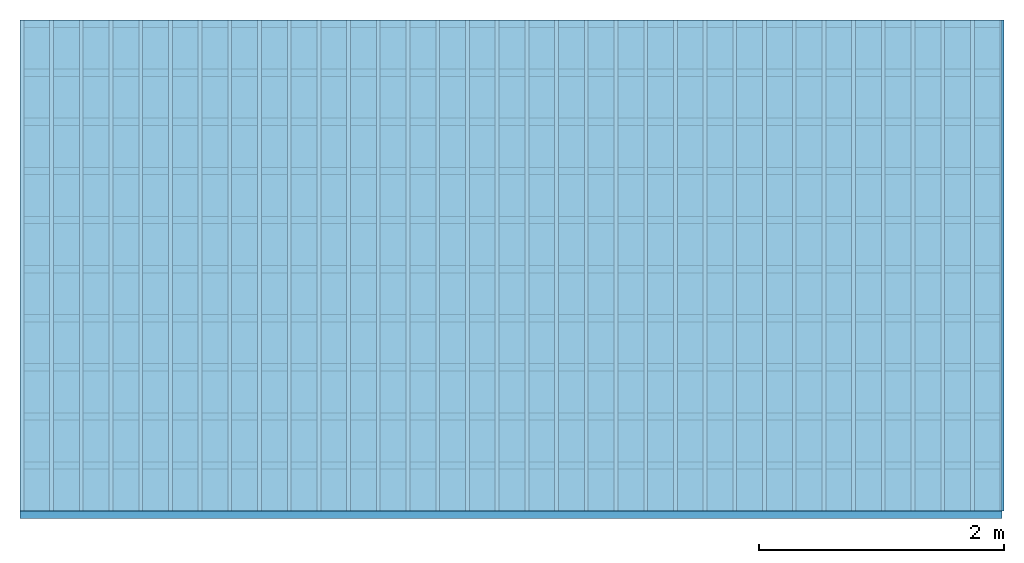
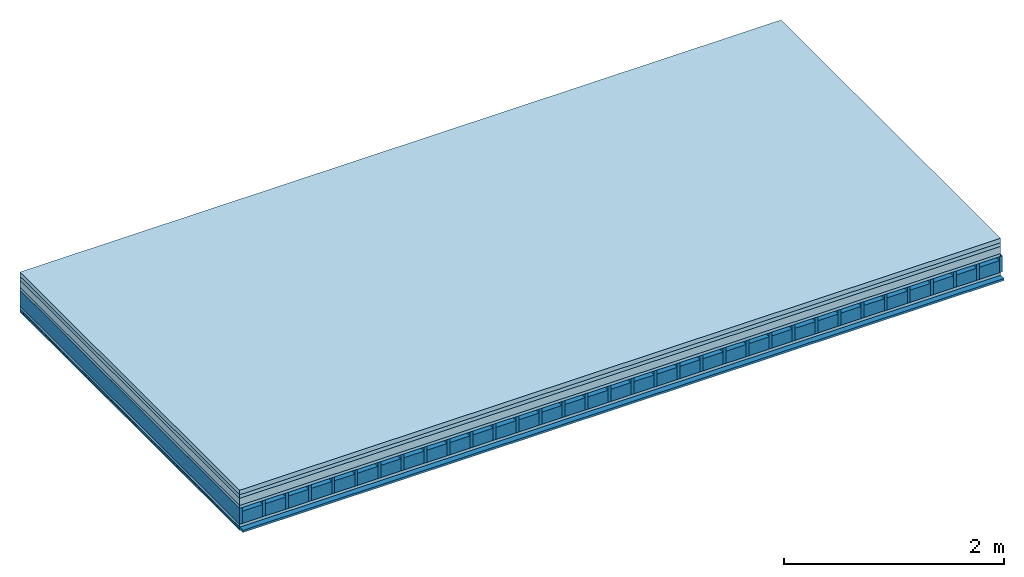
# One storey: 6 plates, 4 members, 1 element without a shape of its own.
"""IFC4 building model written with IfcOpenShell, lengths in metres."""

from ifc_helpers import new_model, si_unit, derived_unit, direction, frame, frame_2d, origin, origin_with_axes, place, context, project, spatial, rectangle, extrude, material, layer, layer_set, type_object, element, aggregate, save


model = new_model("IFC4")

# Units and contexts
plan_context = context("Plan", 3, precision=1e-05, world=origin(), true_north=direction((0.0, 1.0)))
model_context = context("Model", 3, precision=1e-05, world=origin(), true_north=direction((0.0, 1.0)))
ifc_project = project(units=[si_unit("LENGTHUNIT", "METRE"), derived_unit("SOUNDPRESSUREUNIT", [(si_unit("PRESSUREUNIT", "PASCAL", prefix="MICRO"), 0)]), si_unit("ENERGYUNIT", "JOULE", prefix="MEGA"), si_unit("MASSUNIT", "GRAM", prefix="KILO"), derived_unit("THERMALTRANSMITTANCEUNIT", [(si_unit("POWERUNIT", "WATT"), 1), (si_unit("AREAUNIT", "SQUARE_METRE"), -1), (si_unit("THERMODYNAMICTEMPERATUREUNIT", "KELVIN"), -1)]), derived_unit("AREADENSITYUNIT", [(si_unit("MASSUNIT", "GRAM", prefix="KILO"), 1), (si_unit("AREAUNIT", "SQUARE_METRE"), -1)]), derived_unit("USERDEFINED", [(si_unit("ENERGYUNIT", "JOULE", prefix="MEGA"), 1), (si_unit("AREAUNIT", "SQUARE_METRE"), -1)])], contexts=[plan_context, model_context])

# Site, building, storey
site = spatial("IfcSite", under=ifc_project)
building_placement = place(None, origin())
building = spatial("IfcBuilding", under=site, at=building_placement)
storey_placement = place(building_placement, origin())
storey = spatial("IfcBuildingStorey", under=building, at=storey_placement)

# Slab, members, plates
ifc_material_1 = material(Name="Cement screed", Category="04.006")
ifc_layer_1 = layer(ifc_material_1, 0.05, Name="On-material")
ifc_material_2 = material(Name="EP1, 40/35mm")
ifc_layer_2 = layer(ifc_material_2, 0.04, Name="Impact sound insulation")
ifc_material_3 = material(Category="03.011")
ifc_layer_3 = layer(ifc_material_3, 0.08, Name="on Supporting structure")
ifc_material_4 = material(Name="surface element sheathing above")
ifc_layer_4 = layer(ifc_material_4, 0.031, Name="Sub-floor")
ifc_layer_5 = layer(None, 0.178, Name="Supporting structure")
ifc_material_5 = material(Name="surface element sheathing below")
ifc_layer_6 = layer(ifc_material_5, 0.031, Name="Lower layer 1")
ifc_layer_7 = layer(None, 0.024, Name="Battens / profiles")
ifc_material_6 = material(Name="Plasterboard type A", Category="03.008")
ifc_layer_8 = layer(ifc_material_6, 0.0125, Name="Ceiling covering 1st layer")
ifc_material_7 = material(Name="joints", Category="04.017")
ifc_layer_9 = layer(ifc_material_7, 0.0, Name="Surface / treatment")
ifc_layer_set = layer_set([ifc_layer_1, ifc_layer_2, ifc_layer_3, ifc_layer_4, ifc_layer_5, ifc_layer_6, ifc_layer_7, ifc_layer_8, ifc_layer_9])
slab_type = type_object("IfcSlabType", Name="A1468", PredefinedType="NOTDEFINED", material=ifc_layer_set)
slab_placement = place(None, frame((0.0, 0.0, 0.0), z_axis=(0.0, 0.0, -1.0), x_axis=(1.0, 0.0, 0.0)))
slab = element("IfcSlab", 1, at=slab_placement, inside=storey, type_object=slab_type, material=ifc_layer_set, Name="Slab #1")
ifc_material_8 = material(Name="surface element LFE 12")
member_1_placement = place(slab_placement, origin())
member_1 = element("IfcMember", 2, at=member_1_placement, material=ifc_material_8, Name="Supporting structure", context=plan_context, shape_type="SweptSolid", body=[
    extrude(rectangle(XDim=0.031, YDim=0.178, at=frame_2d((0.0155, 0.089), x_axis=(1.0, 0.0))), frame((0.0, 4.0, 0.201), z_axis=(0.0, -1.0, 0.0), x_axis=(1.0, 0.0, 0.0)), (0.0, 0.0, 1.0), 4.0),
    extrude(rectangle(XDim=0.031, YDim=0.178, at=frame_2d((0.0155, 0.089), x_axis=(1.0, 0.0))), frame((0.242, 4.0, 0.201), z_axis=(0.0, -1.0, 0.0), x_axis=(1.0, 0.0, 0.0)), (0.0, 0.0, 1.0), 4.0),
    extrude(rectangle(XDim=0.031, YDim=0.178, at=frame_2d((0.0155, 0.089), x_axis=(1.0, 0.0))), frame((0.484, 4.0, 0.201), z_axis=(0.0, -1.0, 0.0), x_axis=(1.0, 0.0, 0.0)), (0.0, 0.0, 1.0), 4.0),
    extrude(rectangle(XDim=0.031, YDim=0.178, at=frame_2d((0.0155, 0.089), x_axis=(1.0, 0.0))), frame((0.726, 4.0, 0.201), z_axis=(0.0, -1.0, 0.0), x_axis=(1.0, 0.0, 0.0)), (0.0, 0.0, 1.0), 4.0),
    extrude(rectangle(XDim=0.031, YDim=0.178, at=frame_2d((0.0155, 0.089), x_axis=(1.0, 0.0))), frame((0.968, 4.0, 0.201), z_axis=(0.0, -1.0, 0.0), x_axis=(1.0, 0.0, 0.0)), (0.0, 0.0, 1.0), 4.0),
    extrude(rectangle(XDim=0.031, YDim=0.178, at=frame_2d((0.0155, 0.089), x_axis=(1.0, 0.0))), frame((1.21, 4.0, 0.201), z_axis=(0.0, -1.0, 0.0), x_axis=(1.0, 0.0, 0.0)), (0.0, 0.0, 1.0), 4.0),
    extrude(rectangle(XDim=0.031, YDim=0.178, at=frame_2d((0.0155, 0.089), x_axis=(1.0, 0.0))), frame((1.452, 4.0, 0.201), z_axis=(0.0, -1.0, 0.0), x_axis=(1.0, 0.0, 0.0)), (0.0, 0.0, 1.0), 4.0),
    extrude(rectangle(XDim=0.031, YDim=0.178, at=frame_2d((0.0155, 0.089), x_axis=(1.0, 0.0))), frame((1.694, 4.0, 0.201), z_axis=(0.0, -1.0, 0.0), x_axis=(1.0, 0.0, 0.0)), (0.0, 0.0, 1.0), 4.0),
    extrude(rectangle(XDim=0.031, YDim=0.178, at=frame_2d((0.0155, 0.089), x_axis=(1.0, 0.0))), frame((1.936, 4.0, 0.201), z_axis=(0.0, -1.0, 0.0), x_axis=(1.0, 0.0, 0.0)), (0.0, 0.0, 1.0), 4.0),
    extrude(rectangle(XDim=0.031, YDim=0.178, at=frame_2d((0.0155, 0.089), x_axis=(1.0, 0.0))), frame((2.178, 4.0, 0.201), z_axis=(0.0, -1.0, 0.0), x_axis=(1.0, 0.0, 0.0)), (0.0, 0.0, 1.0), 4.0),
    extrude(rectangle(XDim=0.031, YDim=0.178, at=frame_2d((0.0155, 0.089), x_axis=(1.0, 0.0))), frame((2.42, 4.0, 0.201), z_axis=(0.0, -1.0, 0.0), x_axis=(1.0, 0.0, 0.0)), (0.0, 0.0, 1.0), 4.0),
    extrude(rectangle(XDim=0.031, YDim=0.178, at=frame_2d((0.0155, 0.089), x_axis=(1.0, 0.0))), frame((2.662, 4.0, 0.201), z_axis=(0.0, -1.0, 0.0), x_axis=(1.0, 0.0, 0.0)), (0.0, 0.0, 1.0), 4.0),
    extrude(rectangle(XDim=0.031, YDim=0.178, at=frame_2d((0.0155, 0.089), x_axis=(1.0, 0.0))), frame((2.904, 4.0, 0.201), z_axis=(0.0, -1.0, 0.0), x_axis=(1.0, 0.0, 0.0)), (0.0, 0.0, 1.0), 4.0),
    extrude(rectangle(XDim=0.031, YDim=0.178, at=frame_2d((0.0155, 0.089), x_axis=(1.0, 0.0))), frame((3.146, 4.0, 0.201), z_axis=(0.0, -1.0, 0.0), x_axis=(1.0, 0.0, 0.0)), (0.0, 0.0, 1.0), 4.0),
    extrude(rectangle(XDim=0.031, YDim=0.178, at=frame_2d((0.0155, 0.089), x_axis=(1.0, 0.0))), frame((3.388, 4.0, 0.201), z_axis=(0.0, -1.0, 0.0), x_axis=(1.0, 0.0, 0.0)), (0.0, 0.0, 1.0), 4.0),
    extrude(rectangle(XDim=0.031, YDim=0.178, at=frame_2d((0.0155, 0.089), x_axis=(1.0, 0.0))), frame((3.63, 4.0, 0.201), z_axis=(0.0, -1.0, 0.0), x_axis=(1.0, 0.0, 0.0)), (0.0, 0.0, 1.0), 4.0),
    extrude(rectangle(XDim=0.031, YDim=0.178, at=frame_2d((0.0155, 0.089), x_axis=(1.0, 0.0))), frame((3.872, 4.0, 0.201), z_axis=(0.0, -1.0, 0.0), x_axis=(1.0, 0.0, 0.0)), (0.0, 0.0, 1.0), 4.0),
    extrude(rectangle(XDim=0.031, YDim=0.178, at=frame_2d((0.0155, 0.089), x_axis=(1.0, 0.0))), frame((4.114, 4.0, 0.201), z_axis=(0.0, -1.0, 0.0), x_axis=(1.0, 0.0, 0.0)), (0.0, 0.0, 1.0), 4.0),
    extrude(rectangle(XDim=0.031, YDim=0.178, at=frame_2d((0.0155, 0.089), x_axis=(1.0, 0.0))), frame((4.356, 4.0, 0.201), z_axis=(0.0, -1.0, 0.0), x_axis=(1.0, 0.0, 0.0)), (0.0, 0.0, 1.0), 4.0),
    extrude(rectangle(XDim=0.031, YDim=0.178, at=frame_2d((0.0155, 0.089), x_axis=(1.0, 0.0))), frame((4.598, 4.0, 0.201), z_axis=(0.0, -1.0, 0.0), x_axis=(1.0, 0.0, 0.0)), (0.0, 0.0, 1.0), 4.0),
    extrude(rectangle(XDim=0.031, YDim=0.178, at=frame_2d((0.0155, 0.089), x_axis=(1.0, 0.0))), frame((4.84, 4.0, 0.201), z_axis=(0.0, -1.0, 0.0), x_axis=(1.0, 0.0, 0.0)), (0.0, 0.0, 1.0), 4.0),
    extrude(rectangle(XDim=0.031, YDim=0.178, at=frame_2d((0.0155, 0.089), x_axis=(1.0, 0.0))), frame((5.082, 4.0, 0.201), z_axis=(0.0, -1.0, 0.0), x_axis=(1.0, 0.0, 0.0)), (0.0, 0.0, 1.0), 4.0),
    extrude(rectangle(XDim=0.031, YDim=0.178, at=frame_2d((0.0155, 0.089), x_axis=(1.0, 0.0))), frame((5.324, 4.0, 0.201), z_axis=(0.0, -1.0, 0.0), x_axis=(1.0, 0.0, 0.0)), (0.0, 0.0, 1.0), 4.0),
    extrude(rectangle(XDim=0.031, YDim=0.178, at=frame_2d((0.0155, 0.089), x_axis=(1.0, 0.0))), frame((5.566, 4.0, 0.201), z_axis=(0.0, -1.0, 0.0), x_axis=(1.0, 0.0, 0.0)), (0.0, 0.0, 1.0), 4.0),
    extrude(rectangle(XDim=0.031, YDim=0.178, at=frame_2d((0.0155, 0.089), x_axis=(1.0, 0.0))), frame((5.808, 4.0, 0.201), z_axis=(0.0, -1.0, 0.0), x_axis=(1.0, 0.0, 0.0)), (0.0, 0.0, 1.0), 4.0),
    extrude(rectangle(XDim=0.031, YDim=0.178, at=frame_2d((0.0155, 0.089), x_axis=(1.0, 0.0))), frame((6.05, 4.0, 0.201), z_axis=(0.0, -1.0, 0.0), x_axis=(1.0, 0.0, 0.0)), (0.0, 0.0, 1.0), 4.0),
    extrude(rectangle(XDim=0.031, YDim=0.178, at=frame_2d((0.0155, 0.089), x_axis=(1.0, 0.0))), frame((6.292, 4.0, 0.201), z_axis=(0.0, -1.0, 0.0), x_axis=(1.0, 0.0, 0.0)), (0.0, 0.0, 1.0), 4.0),
    extrude(rectangle(XDim=0.031, YDim=0.178, at=frame_2d((0.0155, 0.089), x_axis=(1.0, 0.0))), frame((6.534, 4.0, 0.201), z_axis=(0.0, -1.0, 0.0), x_axis=(1.0, 0.0, 0.0)), (0.0, 0.0, 1.0), 4.0),
    extrude(rectangle(XDim=0.031, YDim=0.178, at=frame_2d((0.0155, 0.089), x_axis=(1.0, 0.0))), frame((6.776, 4.0, 0.201), z_axis=(0.0, -1.0, 0.0), x_axis=(1.0, 0.0, 0.0)), (0.0, 0.0, 1.0), 4.0),
    extrude(rectangle(XDim=0.031, YDim=0.178, at=frame_2d((0.0155, 0.089), x_axis=(1.0, 0.0))), frame((7.018, 4.0, 0.201), z_axis=(0.0, -1.0, 0.0), x_axis=(1.0, 0.0, 0.0)), (0.0, 0.0, 1.0), 4.0),
    extrude(rectangle(XDim=0.031, YDim=0.178, at=frame_2d((0.0155, 0.089), x_axis=(1.0, 0.0))), frame((7.26, 4.0, 0.201), z_axis=(0.0, -1.0, 0.0), x_axis=(1.0, 0.0, 0.0)), (0.0, 0.0, 1.0), 4.0),
    extrude(rectangle(XDim=0.031, YDim=0.178, at=frame_2d((0.0155, 0.089), x_axis=(1.0, 0.0))), frame((7.502, 4.0, 0.201), z_axis=(0.0, -1.0, 0.0), x_axis=(1.0, 0.0, 0.0)), (0.0, 0.0, 1.0), 4.0),
    extrude(rectangle(XDim=0.031, YDim=0.178, at=frame_2d((0.0155, 0.089), x_axis=(1.0, 0.0))), frame((7.744, 4.0, 0.201), z_axis=(0.0, -1.0, 0.0), x_axis=(1.0, 0.0, 0.0)), (0.0, 0.0, 1.0), 4.0),
    extrude(rectangle(XDim=0.031, YDim=0.178, at=frame_2d((0.0155, 0.089), x_axis=(1.0, 0.0))), frame((7.986, 4.0, 0.201), z_axis=(0.0, -1.0, 0.0), x_axis=(1.0, 0.0, 0.0)), (0.0, 0.0, 1.0), 4.0),
])
ifc_material_9 = material(Name="Damper LFE 12")
member_2_placement = place(slab_placement, origin())
member_2 = element("IfcMember", 3, at=member_2_placement, material=ifc_material_9, Name="in supporting structure", context=plan_context, shape_type="SweptSolid", body=[
    extrude(rectangle(XDim=0.211, YDim=0.135, at=frame_2d((0.1055, 0.0675), x_axis=(1.0, 0.0))), frame((0.031, 4.0, 0.244), z_axis=(0.0, -1.0, 0.0), x_axis=(1.0, 0.0, 0.0)), (0.0, 0.0, 1.0), 4.0),
    extrude(rectangle(XDim=0.211, YDim=0.135, at=frame_2d((0.1055, 0.0675), x_axis=(1.0, 0.0))), frame((0.273, 4.0, 0.244), z_axis=(0.0, -1.0, 0.0), x_axis=(1.0, 0.0, 0.0)), (0.0, 0.0, 1.0), 4.0),
    extrude(rectangle(XDim=0.211, YDim=0.135, at=frame_2d((0.1055, 0.0675), x_axis=(1.0, 0.0))), frame((0.515, 4.0, 0.244), z_axis=(0.0, -1.0, 0.0), x_axis=(1.0, 0.0, 0.0)), (0.0, 0.0, 1.0), 4.0),
    extrude(rectangle(XDim=0.211, YDim=0.135, at=frame_2d((0.1055, 0.0675), x_axis=(1.0, 0.0))), frame((0.757, 4.0, 0.244), z_axis=(0.0, -1.0, 0.0), x_axis=(1.0, 0.0, 0.0)), (0.0, 0.0, 1.0), 4.0),
    extrude(rectangle(XDim=0.211, YDim=0.135, at=frame_2d((0.1055, 0.0675), x_axis=(1.0, 0.0))), frame((0.999, 4.0, 0.244), z_axis=(0.0, -1.0, 0.0), x_axis=(1.0, 0.0, 0.0)), (0.0, 0.0, 1.0), 4.0),
    extrude(rectangle(XDim=0.211, YDim=0.135, at=frame_2d((0.1055, 0.0675), x_axis=(1.0, 0.0))), frame((1.241, 4.0, 0.244), z_axis=(0.0, -1.0, 0.0), x_axis=(1.0, 0.0, 0.0)), (0.0, 0.0, 1.0), 4.0),
    extrude(rectangle(XDim=0.211, YDim=0.135, at=frame_2d((0.1055, 0.0675), x_axis=(1.0, 0.0))), frame((1.483, 4.0, 0.244), z_axis=(0.0, -1.0, 0.0), x_axis=(1.0, 0.0, 0.0)), (0.0, 0.0, 1.0), 4.0),
    extrude(rectangle(XDim=0.211, YDim=0.135, at=frame_2d((0.1055, 0.0675), x_axis=(1.0, 0.0))), frame((1.725, 4.0, 0.244), z_axis=(0.0, -1.0, 0.0), x_axis=(1.0, 0.0, 0.0)), (0.0, 0.0, 1.0), 4.0),
    extrude(rectangle(XDim=0.211, YDim=0.135, at=frame_2d((0.1055, 0.0675), x_axis=(1.0, 0.0))), frame((1.967, 4.0, 0.244), z_axis=(0.0, -1.0, 0.0), x_axis=(1.0, 0.0, 0.0)), (0.0, 0.0, 1.0), 4.0),
    extrude(rectangle(XDim=0.211, YDim=0.135, at=frame_2d((0.1055, 0.0675), x_axis=(1.0, 0.0))), frame((2.209, 4.0, 0.244), z_axis=(0.0, -1.0, 0.0), x_axis=(1.0, 0.0, 0.0)), (0.0, 0.0, 1.0), 4.0),
    extrude(rectangle(XDim=0.211, YDim=0.135, at=frame_2d((0.1055, 0.0675), x_axis=(1.0, 0.0))), frame((2.451, 4.0, 0.244), z_axis=(0.0, -1.0, 0.0), x_axis=(1.0, 0.0, 0.0)), (0.0, 0.0, 1.0), 4.0),
    extrude(rectangle(XDim=0.211, YDim=0.135, at=frame_2d((0.1055, 0.0675), x_axis=(1.0, 0.0))), frame((2.693, 4.0, 0.244), z_axis=(0.0, -1.0, 0.0), x_axis=(1.0, 0.0, 0.0)), (0.0, 0.0, 1.0), 4.0),
    extrude(rectangle(XDim=0.211, YDim=0.135, at=frame_2d((0.1055, 0.0675), x_axis=(1.0, 0.0))), frame((2.935, 4.0, 0.244), z_axis=(0.0, -1.0, 0.0), x_axis=(1.0, 0.0, 0.0)), (0.0, 0.0, 1.0), 4.0),
    extrude(rectangle(XDim=0.211, YDim=0.135, at=frame_2d((0.1055, 0.0675), x_axis=(1.0, 0.0))), frame((3.177, 4.0, 0.244), z_axis=(0.0, -1.0, 0.0), x_axis=(1.0, 0.0, 0.0)), (0.0, 0.0, 1.0), 4.0),
    extrude(rectangle(XDim=0.211, YDim=0.135, at=frame_2d((0.1055, 0.0675), x_axis=(1.0, 0.0))), frame((3.419, 4.0, 0.244), z_axis=(0.0, -1.0, 0.0), x_axis=(1.0, 0.0, 0.0)), (0.0, 0.0, 1.0), 4.0),
    extrude(rectangle(XDim=0.211, YDim=0.135, at=frame_2d((0.1055, 0.0675), x_axis=(1.0, 0.0))), frame((3.661, 4.0, 0.244), z_axis=(0.0, -1.0, 0.0), x_axis=(1.0, 0.0, 0.0)), (0.0, 0.0, 1.0), 4.0),
    extrude(rectangle(XDim=0.211, YDim=0.135, at=frame_2d((0.1055, 0.0675), x_axis=(1.0, 0.0))), frame((3.903, 4.0, 0.244), z_axis=(0.0, -1.0, 0.0), x_axis=(1.0, 0.0, 0.0)), (0.0, 0.0, 1.0), 4.0),
    extrude(rectangle(XDim=0.211, YDim=0.135, at=frame_2d((0.1055, 0.0675), x_axis=(1.0, 0.0))), frame((4.145, 4.0, 0.244), z_axis=(0.0, -1.0, 0.0), x_axis=(1.0, 0.0, 0.0)), (0.0, 0.0, 1.0), 4.0),
    extrude(rectangle(XDim=0.211, YDim=0.135, at=frame_2d((0.1055, 0.0675), x_axis=(1.0, 0.0))), frame((4.387, 4.0, 0.244), z_axis=(0.0, -1.0, 0.0), x_axis=(1.0, 0.0, 0.0)), (0.0, 0.0, 1.0), 4.0),
    extrude(rectangle(XDim=0.211, YDim=0.135, at=frame_2d((0.1055, 0.0675), x_axis=(1.0, 0.0))), frame((4.629, 4.0, 0.244), z_axis=(0.0, -1.0, 0.0), x_axis=(1.0, 0.0, 0.0)), (0.0, 0.0, 1.0), 4.0),
    extrude(rectangle(XDim=0.211, YDim=0.135, at=frame_2d((0.1055, 0.0675), x_axis=(1.0, 0.0))), frame((4.871, 4.0, 0.244), z_axis=(0.0, -1.0, 0.0), x_axis=(1.0, 0.0, 0.0)), (0.0, 0.0, 1.0), 4.0),
    extrude(rectangle(XDim=0.211, YDim=0.135, at=frame_2d((0.1055, 0.0675), x_axis=(1.0, 0.0))), frame((5.113, 4.0, 0.244), z_axis=(0.0, -1.0, 0.0), x_axis=(1.0, 0.0, 0.0)), (0.0, 0.0, 1.0), 4.0),
    extrude(rectangle(XDim=0.211, YDim=0.135, at=frame_2d((0.1055, 0.0675), x_axis=(1.0, 0.0))), frame((5.355, 4.0, 0.244), z_axis=(0.0, -1.0, 0.0), x_axis=(1.0, 0.0, 0.0)), (0.0, 0.0, 1.0), 4.0),
    extrude(rectangle(XDim=0.211, YDim=0.135, at=frame_2d((0.1055, 0.0675), x_axis=(1.0, 0.0))), frame((5.597, 4.0, 0.244), z_axis=(0.0, -1.0, 0.0), x_axis=(1.0, 0.0, 0.0)), (0.0, 0.0, 1.0), 4.0),
    extrude(rectangle(XDim=0.211, YDim=0.135, at=frame_2d((0.1055, 0.0675), x_axis=(1.0, 0.0))), frame((5.839, 4.0, 0.244), z_axis=(0.0, -1.0, 0.0), x_axis=(1.0, 0.0, 0.0)), (0.0, 0.0, 1.0), 4.0),
    extrude(rectangle(XDim=0.211, YDim=0.135, at=frame_2d((0.1055, 0.0675), x_axis=(1.0, 0.0))), frame((6.081, 4.0, 0.244), z_axis=(0.0, -1.0, 0.0), x_axis=(1.0, 0.0, 0.0)), (0.0, 0.0, 1.0), 4.0),
    extrude(rectangle(XDim=0.211, YDim=0.135, at=frame_2d((0.1055, 0.0675), x_axis=(1.0, 0.0))), frame((6.323, 4.0, 0.244), z_axis=(0.0, -1.0, 0.0), x_axis=(1.0, 0.0, 0.0)), (0.0, 0.0, 1.0), 4.0),
    extrude(rectangle(XDim=0.211, YDim=0.135, at=frame_2d((0.1055, 0.0675), x_axis=(1.0, 0.0))), frame((6.565, 4.0, 0.244), z_axis=(0.0, -1.0, 0.0), x_axis=(1.0, 0.0, 0.0)), (0.0, 0.0, 1.0), 4.0),
    extrude(rectangle(XDim=0.211, YDim=0.135, at=frame_2d((0.1055, 0.0675), x_axis=(1.0, 0.0))), frame((6.807, 4.0, 0.244), z_axis=(0.0, -1.0, 0.0), x_axis=(1.0, 0.0, 0.0)), (0.0, 0.0, 1.0), 4.0),
    extrude(rectangle(XDim=0.211, YDim=0.135, at=frame_2d((0.1055, 0.0675), x_axis=(1.0, 0.0))), frame((7.049, 4.0, 0.244), z_axis=(0.0, -1.0, 0.0), x_axis=(1.0, 0.0, 0.0)), (0.0, 0.0, 1.0), 4.0),
    extrude(rectangle(XDim=0.211, YDim=0.135, at=frame_2d((0.1055, 0.0675), x_axis=(1.0, 0.0))), frame((7.291, 4.0, 0.244), z_axis=(0.0, -1.0, 0.0), x_axis=(1.0, 0.0, 0.0)), (0.0, 0.0, 1.0), 4.0),
    extrude(rectangle(XDim=0.211, YDim=0.135, at=frame_2d((0.1055, 0.0675), x_axis=(1.0, 0.0))), frame((7.533, 4.0, 0.244), z_axis=(0.0, -1.0, 0.0), x_axis=(1.0, 0.0, 0.0)), (0.0, 0.0, 1.0), 4.0),
    extrude(rectangle(XDim=0.211, YDim=0.135, at=frame_2d((0.1055, 0.0675), x_axis=(1.0, 0.0))), frame((7.775, 4.0, 0.244), z_axis=(0.0, -1.0, 0.0), x_axis=(1.0, 0.0, 0.0)), (0.0, 0.0, 1.0), 4.0),
])
ifc_material_10 = material()
member_3_placement = place(slab_placement, origin())
member_3 = element("IfcMember", 4, at=member_3_placement, material=ifc_material_10, Name="Battens / profiles", context=plan_context, shape_type="SweptSolid", body=[
    extrude(rectangle(XDim=0.06, YDim=0.024, at=frame_2d((0.03, 0.012), x_axis=(1.0, 0.0))), frame((0.0, 0.0, 0.41), z_axis=(1.0, 0.0, 0.0), x_axis=(0.0, 1.0, 0.0)), (0.0, 0.0, 1.0), 8.0),
    extrude(rectangle(XDim=0.06, YDim=0.024, at=frame_2d((0.03, 0.012), x_axis=(1.0, 0.0))), frame((0.0, 0.4, 0.41), z_axis=(1.0, 0.0, 0.0), x_axis=(0.0, 1.0, 0.0)), (0.0, 0.0, 1.0), 8.0),
    extrude(rectangle(XDim=0.06, YDim=0.024, at=frame_2d((0.03, 0.012), x_axis=(1.0, 0.0))), frame((0.0, 0.8, 0.41), z_axis=(1.0, 0.0, 0.0), x_axis=(0.0, 1.0, 0.0)), (0.0, 0.0, 1.0), 8.0),
    extrude(rectangle(XDim=0.06, YDim=0.024, at=frame_2d((0.03, 0.012), x_axis=(1.0, 0.0))), frame((0.0, 1.2, 0.41), z_axis=(1.0, 0.0, 0.0), x_axis=(0.0, 1.0, 0.0)), (0.0, 0.0, 1.0), 8.0),
    extrude(rectangle(XDim=0.06, YDim=0.024, at=frame_2d((0.03, 0.012), x_axis=(1.0, 0.0))), frame((0.0, 1.6, 0.41), z_axis=(1.0, 0.0, 0.0), x_axis=(0.0, 1.0, 0.0)), (0.0, 0.0, 1.0), 8.0),
    extrude(rectangle(XDim=0.06, YDim=0.024, at=frame_2d((0.03, 0.012), x_axis=(1.0, 0.0))), frame((0.0, 2.0, 0.41), z_axis=(1.0, 0.0, 0.0), x_axis=(0.0, 1.0, 0.0)), (0.0, 0.0, 1.0), 8.0),
    extrude(rectangle(XDim=0.06, YDim=0.024, at=frame_2d((0.03, 0.012), x_axis=(1.0, 0.0))), frame((0.0, 2.4, 0.41), z_axis=(1.0, 0.0, 0.0), x_axis=(0.0, 1.0, 0.0)), (0.0, 0.0, 1.0), 8.0),
    extrude(rectangle(XDim=0.06, YDim=0.024, at=frame_2d((0.03, 0.012), x_axis=(1.0, 0.0))), frame((0.0, 2.8, 0.41), z_axis=(1.0, 0.0, 0.0), x_axis=(0.0, 1.0, 0.0)), (0.0, 0.0, 1.0), 8.0),
    extrude(rectangle(XDim=0.06, YDim=0.024, at=frame_2d((0.03, 0.012), x_axis=(1.0, 0.0))), frame((0.0, 3.2, 0.41), z_axis=(1.0, 0.0, 0.0), x_axis=(0.0, 1.0, 0.0)), (0.0, 0.0, 1.0), 8.0),
    extrude(rectangle(XDim=0.06, YDim=0.024, at=frame_2d((0.03, 0.012), x_axis=(1.0, 0.0))), frame((0.0, 3.6, 0.41), z_axis=(1.0, 0.0, 0.0), x_axis=(0.0, 1.0, 0.0)), (0.0, 0.0, 1.0), 8.0),
    extrude(rectangle(XDim=0.06, YDim=0.024, at=frame_2d((0.03, 0.012), x_axis=(1.0, 0.0))), frame((0.0, 4.0, 0.41), z_axis=(1.0, 0.0, 0.0), x_axis=(0.0, 1.0, 0.0)), (0.0, 0.0, 1.0), 8.0),
])
ifc_material_11 = material()
member_4_placement = place(slab_placement, origin())
member_4 = element("IfcMember", 5, at=member_4_placement, material=ifc_material_11, Name="Cavity", context=plan_context, shape_type="SweptSolid", body=[
    extrude(rectangle(XDim=0.34, YDim=0.02, at=frame_2d((0.17, 0.01), x_axis=(1.0, 0.0))), frame((0.0, 0.06, 0.414), z_axis=(1.0, 0.0, 0.0), x_axis=(0.0, 1.0, 0.0)), (0.0, 0.0, 1.0), 8.0),
    extrude(rectangle(XDim=0.34, YDim=0.02, at=frame_2d((0.17, 0.01), x_axis=(1.0, 0.0))), frame((0.0, 0.46, 0.414), z_axis=(1.0, 0.0, 0.0), x_axis=(0.0, 1.0, 0.0)), (0.0, 0.0, 1.0), 8.0),
    extrude(rectangle(XDim=0.34, YDim=0.02, at=frame_2d((0.17, 0.01), x_axis=(1.0, 0.0))), frame((0.0, 0.86, 0.414), z_axis=(1.0, 0.0, 0.0), x_axis=(0.0, 1.0, 0.0)), (0.0, 0.0, 1.0), 8.0),
    extrude(rectangle(XDim=0.34, YDim=0.02, at=frame_2d((0.17, 0.01), x_axis=(1.0, 0.0))), frame((0.0, 1.26, 0.414), z_axis=(1.0, 0.0, 0.0), x_axis=(0.0, 1.0, 0.0)), (0.0, 0.0, 1.0), 8.0),
    extrude(rectangle(XDim=0.34, YDim=0.02, at=frame_2d((0.17, 0.01), x_axis=(1.0, 0.0))), frame((0.0, 1.66, 0.414), z_axis=(1.0, 0.0, 0.0), x_axis=(0.0, 1.0, 0.0)), (0.0, 0.0, 1.0), 8.0),
    extrude(rectangle(XDim=0.34, YDim=0.02, at=frame_2d((0.17, 0.01), x_axis=(1.0, 0.0))), frame((0.0, 2.06, 0.414), z_axis=(1.0, 0.0, 0.0), x_axis=(0.0, 1.0, 0.0)), (0.0, 0.0, 1.0), 8.0),
    extrude(rectangle(XDim=0.34, YDim=0.02, at=frame_2d((0.17, 0.01), x_axis=(1.0, 0.0))), frame((0.0, 2.46, 0.414), z_axis=(1.0, 0.0, 0.0), x_axis=(0.0, 1.0, 0.0)), (0.0, 0.0, 1.0), 8.0),
    extrude(rectangle(XDim=0.34, YDim=0.02, at=frame_2d((0.17, 0.01), x_axis=(1.0, 0.0))), frame((0.0, 2.86, 0.414), z_axis=(1.0, 0.0, 0.0), x_axis=(0.0, 1.0, 0.0)), (0.0, 0.0, 1.0), 8.0),
    extrude(rectangle(XDim=0.34, YDim=0.02, at=frame_2d((0.17, 0.01), x_axis=(1.0, 0.0))), frame((0.0, 3.26, 0.414), z_axis=(1.0, 0.0, 0.0), x_axis=(0.0, 1.0, 0.0)), (0.0, 0.0, 1.0), 8.0),
    extrude(rectangle(XDim=0.34, YDim=0.02, at=frame_2d((0.17, 0.01), x_axis=(1.0, 0.0))), frame((0.0, 3.66, 0.414), z_axis=(1.0, 0.0, 0.0), x_axis=(0.0, 1.0, 0.0)), (0.0, 0.0, 1.0), 8.0),
])
plate_1_placement = place(slab_placement, origin())
plate_1 = element("IfcPlate", 6, at=plate_1_placement, material=ifc_material_1, Name="On-material", context=plan_context, shape_type="SweptSolid", body=[
    extrude(rectangle(XDim=8.0, YDim=4.0, at=frame_2d((4.0, 2.0), x_axis=(1.0, 0.0))), origin_with_axes(), (0.0, 0.0, 1.0), 0.05),
])
plate_2_placement = place(slab_placement, origin())
plate_2 = element("IfcPlate", 7, at=plate_2_placement, material=ifc_material_2, Name="Impact sound insulation", context=plan_context, shape_type="SweptSolid", body=[
    extrude(rectangle(XDim=8.0, YDim=4.0, at=frame_2d((4.0, 2.0), x_axis=(1.0, 0.0))), frame((0.0, 0.0, 0.05), z_axis=(0.0, 0.0, 1.0), x_axis=(1.0, 0.0, 0.0)), (0.0, 0.0, 1.0), 0.04),
])
plate_3_placement = place(slab_placement, origin())
plate_3 = element("IfcPlate", 8, at=plate_3_placement, material=ifc_material_3, Name="on Supporting structure", context=plan_context, shape_type="SweptSolid", body=[
    extrude(rectangle(XDim=8.0, YDim=4.0, at=frame_2d((4.0, 2.0), x_axis=(1.0, 0.0))), frame((0.0, 0.0, 0.09), z_axis=(0.0, 0.0, 1.0), x_axis=(1.0, 0.0, 0.0)), (0.0, 0.0, 1.0), 0.08),
])
plate_4_placement = place(slab_placement, origin())
plate_4 = element("IfcPlate", 9, at=plate_4_placement, material=ifc_material_4, Name="Sub-floor", context=plan_context, shape_type="SweptSolid", body=[
    extrude(rectangle(XDim=8.0, YDim=4.0, at=frame_2d((4.0, 2.0), x_axis=(1.0, 0.0))), frame((0.0, 0.0, 0.17), z_axis=(0.0, 0.0, 1.0), x_axis=(1.0, 0.0, 0.0)), (0.0, 0.0, 1.0), 0.031),
])
plate_5_placement = place(slab_placement, origin())
plate_5 = element("IfcPlate", 10, at=plate_5_placement, material=ifc_material_5, Name="Lower layer 1", context=plan_context, shape_type="SweptSolid", body=[
    extrude(rectangle(XDim=8.0, YDim=4.0, at=frame_2d((4.0, 2.0), x_axis=(1.0, 0.0))), frame((0.0, 0.0, 0.379), z_axis=(0.0, 0.0, 1.0), x_axis=(1.0, 0.0, 0.0)), (0.0, 0.0, 1.0), 0.031),
])
plate_6_placement = place(slab_placement, origin())
plate_6 = element("IfcPlate", 11, at=plate_6_placement, material=ifc_material_6, Name="Ceiling covering 1st layer", context=plan_context, shape_type="SweptSolid", body=[
    extrude(rectangle(XDim=8.0, YDim=4.0, at=frame_2d((4.0, 2.0), x_axis=(1.0, 0.0))), frame((0.0, 0.0, 0.434), z_axis=(0.0, 0.0, 1.0), x_axis=(1.0, 0.0, 0.0)), (0.0, 0.0, 1.0), 0.0125),
])
aggregate(slab, [plate_1, plate_2, plate_3, plate_4, member_1, member_2, plate_5, member_3, member_4, plate_6])

save(model, "model.ifc")
